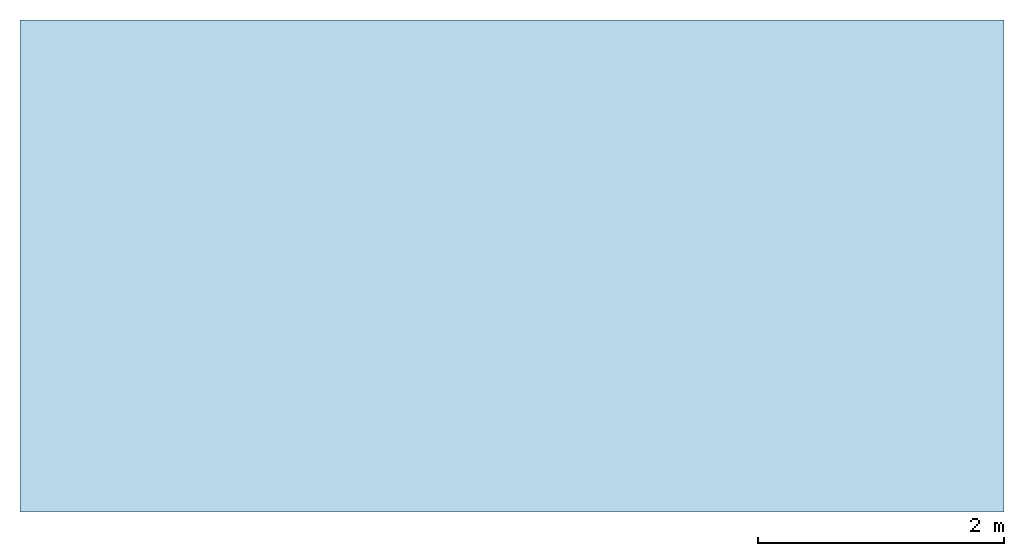
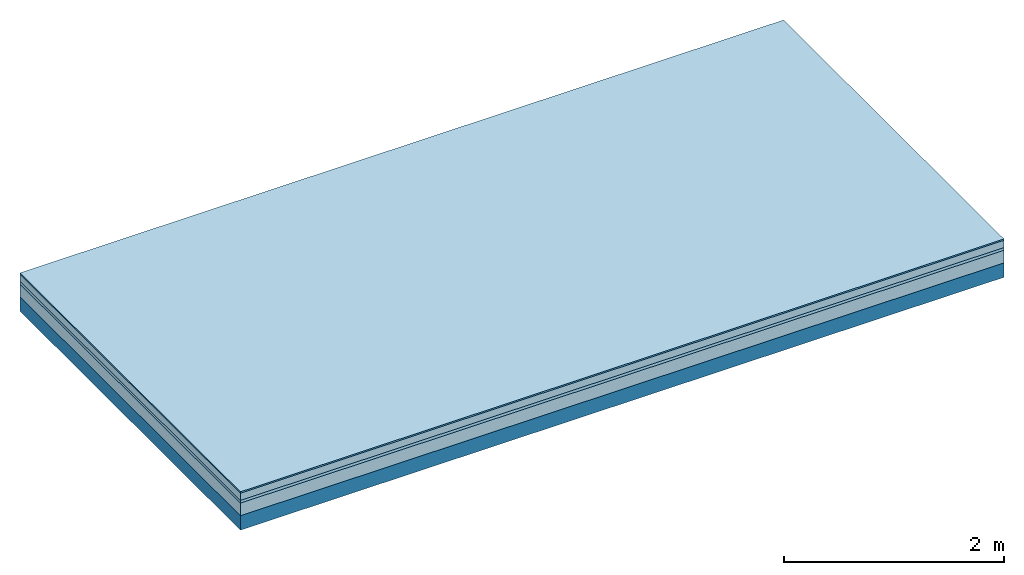
# One storey: 4 plates, 1 member, 1 element without a shape of its own.
"""IFC4 building model written with IfcOpenShell, lengths in metres."""

import ifcopenshell
import ifcopenshell.guid

model = None  # the IFC model being written
_history = None  # IfcOwnerHistory: only IFC2X3 demands one
_inside = {}  # id of a spatial element -> (the spatial element, [elements in it])
_under = {}  # id of a project, library or spatial element -> (it, [spatial elements below it])
_declared = {}  # id of a project -> (the project, [libraries it declares])
_typed = {}  # id of a type object -> (the type object, [elements of that type])
_made_of = {}  # id of a material, layer set ... -> (it, [elements and type objects made of it])


def new_model(schema):
    """Start an empty IFC model of exactly this schema.

    Asked for "IFC4X3", IfcOpenShell would pick the latest addendum, in which some entities
    have other attributes; the version numbers below select the first issue.
    IFC2X3 requires an IfcOwnerHistory on every rooted entity: one is made here for all.
    """
    global model, _history
    if schema == "IFC4X3":
        model = ifcopenshell.file(schema_version=(4, 3, 0, 0))
    else:
        model = ifcopenshell.file(schema=schema)
    _inside.clear()
    _under.clear()
    _declared.clear()
    _typed.clear()
    _made_of.clear()
    _history = None
    if model.schema == "IFC2X3":
        org = make("IfcOrganization", Name="unknown")
        user = make(
            "IfcPersonAndOrganization",
            ThePerson=make("IfcPerson", FamilyName="unknown"),
            TheOrganization=org,
        )
        app = make(
            "IfcApplication",
            ApplicationDeveloper=org,
            Version="unknown",
            ApplicationFullName="unknown",
            ApplicationIdentifier="unknown",
        )
        _history = make(
            "IfcOwnerHistory",
            OwningUser=user,
            OwningApplication=app,
            ChangeAction="ADDED",
            CreationDate=0,
        )
    return model


def make(cls, **values):
    """One entity of the class cls with the attributes given. An attribute that is None is left unset."""
    return model.create_entity(
        cls, **{name: value for name, value in values.items() if value is not None}
    )


def rooted(cls, **values):
    """An entity with a GlobalId (a new one), such as an element, a storey or a relation."""
    return make(cls, GlobalId=ifcopenshell.guid.new(), OwnerHistory=_history, **values)


def si_unit(unit_type, name, prefix=None):
    """IfcSIUnit, for example si_unit("LENGTHUNIT", "METRE", prefix="MILLI")."""
    return make("IfcSIUnit", UnitType=unit_type, Prefix=prefix, Name=name)


def derived_unit(unit_type, elements):
    """IfcDerivedUnit: a product of units, each with its exponent."""
    return make(
        "IfcDerivedUnit",
        Elements=[
            make("IfcDerivedUnitElement", Unit=unit, Exponent=power)
            for unit, power in elements
        ],
        UnitType=unit_type,
    )


def assignment(units):
    """IfcUnitAssignment: the units of a project."""
    return None if units is None else make("IfcUnitAssignment", Units=units)


def point(xyz):
    """IfcCartesianPoint."""
    return None if xyz is None else make("IfcCartesianPoint", Coordinates=xyz)


def direction(xyz):
    """IfcDirection."""
    return None if xyz is None else make("IfcDirection", DirectionRatios=xyz)


def frame(location, z_axis=None, x_axis=None):
    """IfcAxis2Placement3D, a coordinate frame: its origin and axes. An axis left out is left unset."""
    return make(
        "IfcAxis2Placement3D",
        Location=point(location),
        Axis=direction(z_axis),
        RefDirection=direction(x_axis),
    )


def frame_2d(location, x_axis=None):
    """IfcAxis2Placement2D, a coordinate frame in the plane: its origin and x axis."""
    return make(
        "IfcAxis2Placement2D", Location=point(location), RefDirection=direction(x_axis)
    )


def origin():
    """The frame at (0, 0, 0) with its axes left unset."""
    return frame((0.0, 0.0, 0.0))


def origin_with_axes():
    """The frame at (0, 0, 0) with the z axis (0, 0, 1) and the x axis (1, 0, 0) written out."""
    return frame((0.0, 0.0, 0.0), z_axis=(0.0, 0.0, 1.0), x_axis=(1.0, 0.0, 0.0))


def place(relative_to, where):
    """IfcLocalPlacement: puts the frame where relative to a parent placement (None: the world)."""
    return make(
        "IfcLocalPlacement", PlacementRelTo=relative_to, RelativePlacement=where
    )


def context(
    kind, dimensions, precision=None, world=None, true_north=None, identifier=None
):
    """IfcGeometricRepresentationContext, for example the 3D "Model" context."""
    return make(
        "IfcGeometricRepresentationContext",
        ContextIdentifier=identifier,
        ContextType=kind,
        CoordinateSpaceDimension=dimensions,
        Precision=precision,
        WorldCoordinateSystem=world,
        TrueNorth=true_north,
    )


def project(units=None, contexts=None):
    """IfcProject with its units and contexts."""
    return rooted(
        "IfcProject",
        Name="project",
        RepresentationContexts=contexts,
        UnitsInContext=assignment(units),
    )


def spatial(cls, under=None, at=None, **own):
    """A site, building, storey or space (cls), placed at a placement, below another one or the project."""
    s = rooted(cls, ObjectPlacement=at, **own)
    if under is not None:
        _under.setdefault(under.id(), (under, []))[1].append(s)
    return s


def profile(cls, at=None, kind="AREA", **sizes):
    """A parametric profile (cls). Its sizes go by their IFC names, for example OverallWidth=200.0."""
    return make(cls, ProfileType=kind, Position=at, **sizes)


def rectangle(**sizes):
    """IfcRectangleProfileDef."""
    return profile("IfcRectangleProfileDef", **sizes)


def extrude(swept, where, along, depth):
    """IfcExtrudedAreaSolid: the profile swept, set in the frame where, extruded along a direction by depth."""
    return make(
        "IfcExtrudedAreaSolid",
        SweptArea=swept,
        Position=where,
        ExtrudedDirection=direction(along),
        Depth=depth,
    )


def shape(context_of_items, identifier, shape_type, items):
    """IfcShapeRepresentation: the items that make up one representation, for example the "Body"."""
    return make(
        "IfcShapeRepresentation",
        ContextOfItems=context_of_items,
        RepresentationIdentifier=identifier,
        RepresentationType=shape_type,
        Items=items,
    )


def material(Name=None, Category=None):
    """IfcMaterial."""
    return make("IfcMaterial", Name=Name, Category=Category)


def layer(
    of_material, thickness, ventilated=None, Name=None, Category=None, Priority=None
):
    """IfcMaterialLayer: one layer of a wall or slab, of a material (None: an air gap)."""
    return make(
        "IfcMaterialLayer",
        Material=of_material,
        LayerThickness=thickness,
        IsVentilated=ventilated,
        Name=Name,
        Category=Category,
        Priority=Priority,
    )


def layer_set(layers, Name=None):
    """IfcMaterialLayerSet."""
    return make("IfcMaterialLayerSet", MaterialLayers=layers, LayerSetName=Name)


def made_of(thing, what):
    """Note that an element or type object is made of a material, layer set ...; save() writes the relation."""
    if what is not None:
        _made_of.setdefault(what.id(), (what, []))[1].append(thing)
    return thing


def type_object(cls, material=None, **own):
    """A type object (cls), such as IfcWallType, which elements share."""
    return made_of(rooted(cls, **own), material)


def element(
    cls,
    number,
    at=None,
    inside=None,
    cuts=None,
    type_object=None,
    material=None,
    context=None,
    identifier="Body",
    shape_type=None,
    held_by="IfcProductDefinitionShape",
    body=None,
    shapes=None,
    **own,
):
    """One element of the class cls, such as IfcWall. Its Tag is "e" and its number.

    at: its placement. inside: the storey or other place that contains it. cuts: it is an
    opening in that element (IfcRelVoidsElement). A single representation is given by context,
    identifier, shape_type and body (its items); several are given by shapes. held_by: the class
    of the entity that holds the representations. save() writes the other relations.
    """
    e = rooted(cls, Tag="e%d" % number, ObjectPlacement=at, **own)
    if body is not None:
        shapes = [shape(context, identifier, shape_type, body)]
    if shapes is not None:
        e.Representation = make(held_by, Representations=shapes)
    if inside is not None:
        _inside.setdefault(inside.id(), (inside, []))[1].append(e)
    if cuts is not None:
        rooted(
            "IfcRelVoidsElement", RelatingBuildingElement=cuts, RelatedOpeningElement=e
        )
    if type_object is not None:
        _typed.setdefault(type_object.id(), (type_object, []))[1].append(e)
    return made_of(e, material)


def aggregate(whole, parts):
    """IfcRelAggregates: a whole, such as a stair, and the parts it consists of."""
    return rooted("IfcRelAggregates", RelatingObject=whole, RelatedObjects=parts)


def save(model, path):
    """Write the relations noted so far, then the file.

    IfcRelAggregates (storeys below a building ...), IfcRelContainedInSpatialStructure (elements
    in a storey), IfcRelDefinesByType, IfcRelAssociatesMaterial and IfcRelDeclares: one each for
    every whole, place, type object, material and project.
    """
    for whole, parts in _under.values():
        aggregate(whole, parts)
    for where, things in _inside.values():
        rooted(
            "IfcRelContainedInSpatialStructure",
            RelatedElements=things,
            RelatingStructure=where,
        )
    for kind, things in _typed.values():
        rooted("IfcRelDefinesByType", RelatedObjects=things, RelatingType=kind)
    for what, things in _made_of.values():
        rooted("IfcRelAssociatesMaterial", RelatedObjects=things, RelatingMaterial=what)
    for by, libraries in _declared.values():
        rooted("IfcRelDeclares", RelatingContext=by, RelatedDefinitions=libraries)
    model.write(path)


model = new_model("IFC4")

# Units and contexts
plan_context = context("Plan", 3, precision=1e-05, world=origin(), true_north=direction((0.0, 1.0)))
model_context = context("Model", 3, precision=1e-05, world=origin(), true_north=direction((0.0, 1.0)))
ifc_project = project(units=[si_unit("LENGTHUNIT", "METRE"), derived_unit("SOUNDPRESSUREUNIT", [(si_unit("PRESSUREUNIT", "PASCAL", prefix="MICRO"), 0)]), si_unit("ENERGYUNIT", "JOULE", prefix="MEGA"), si_unit("MASSUNIT", "GRAM", prefix="KILO"), derived_unit("THERMALTRANSMITTANCEUNIT", [(si_unit("POWERUNIT", "WATT"), 1), (si_unit("AREAUNIT", "SQUARE_METRE"), -1), (si_unit("THERMODYNAMICTEMPERATUREUNIT", "KELVIN"), -1)]), derived_unit("AREADENSITYUNIT", [(si_unit("MASSUNIT", "GRAM", prefix="KILO"), 1), (si_unit("AREAUNIT", "SQUARE_METRE"), -1)]), derived_unit("USERDEFINED", [(si_unit("ENERGYUNIT", "JOULE", prefix="MEGA"), 1), (si_unit("AREAUNIT", "SQUARE_METRE"), -1)])], contexts=[plan_context, model_context])

# Site, building, storey
site = spatial("IfcSite", under=ifc_project)
building_placement = place(None, origin())
building = spatial("IfcBuilding", under=site, at=building_placement)
storey_placement = place(building_placement, origin())
storey = spatial("IfcBuildingStorey", under=building, at=storey_placement)

# Slab, member, plates
ifc_material_1 = material(Category="11.013")
ifc_layer_1 = layer(ifc_material_1, 0.015, Name="Flooring")
ifc_material_2 = material(Name="Cement screed", Category="04.006")
ifc_layer_2 = layer(ifc_material_2, 0.08, Name="On-material")
ifc_material_3 = material(Name="Wood fiber generic product", Category="10.009")
ifc_layer_3 = layer(ifc_material_3, 0.03, Name="Impact sound insulation")
ifc_material_4 = material(Category="01.002")
ifc_layer_4 = layer(ifc_material_4, 0.14, Name="Sub-floor")
ifc_material_5 = material(Name="Rigid, of the art")
ifc_layer_5 = layer(ifc_material_5, 0.0, Name="Bond")
ifc_layer_6 = layer(None, 0.16, Name="Supporting structure")
ifc_layer_set = layer_set([ifc_layer_1, ifc_layer_2, ifc_layer_3, ifc_layer_4, ifc_layer_5, ifc_layer_6])
slab_type = type_object("IfcSlabType", Name="A2202", PredefinedType="NOTDEFINED", material=ifc_layer_set)
slab_placement = place(None, frame((0.0, 0.0, 0.0), z_axis=(0.0, 0.0, -1.0), x_axis=(1.0, 0.0, 0.0)))
slab = element("IfcSlab", 1, at=slab_placement, inside=storey, type_object=slab_type, material=ifc_layer_set, Name="Slab #1")
ifc_material_6 = material(Name="Solid timber panel")
member_placement = place(slab_placement, origin())
member = element("IfcMember", 2, at=member_placement, material=ifc_material_6, Name="Supporting structure", context=plan_context, shape_type="SweptSolid", body=[
    extrude(rectangle(XDim=1.0, YDim=0.16, at=frame_2d((0.5, 0.08), x_axis=(1.0, 0.0))), frame((0.0, 4.0, 0.265), z_axis=(0.0, -1.0, 0.0), x_axis=(1.0, 0.0, 0.0)), (0.0, 0.0, 1.0), 4.0),
    extrude(rectangle(XDim=1.0, YDim=0.16, at=frame_2d((0.5, 0.08), x_axis=(1.0, 0.0))), frame((1.0, 4.0, 0.265), z_axis=(0.0, -1.0, 0.0), x_axis=(1.0, 0.0, 0.0)), (0.0, 0.0, 1.0), 4.0),
    extrude(rectangle(XDim=1.0, YDim=0.16, at=frame_2d((0.5, 0.08), x_axis=(1.0, 0.0))), frame((2.0, 4.0, 0.265), z_axis=(0.0, -1.0, 0.0), x_axis=(1.0, 0.0, 0.0)), (0.0, 0.0, 1.0), 4.0),
    extrude(rectangle(XDim=1.0, YDim=0.16, at=frame_2d((0.5, 0.08), x_axis=(1.0, 0.0))), frame((3.0, 4.0, 0.265), z_axis=(0.0, -1.0, 0.0), x_axis=(1.0, 0.0, 0.0)), (0.0, 0.0, 1.0), 4.0),
    extrude(rectangle(XDim=1.0, YDim=0.16, at=frame_2d((0.5, 0.08), x_axis=(1.0, 0.0))), frame((4.0, 4.0, 0.265), z_axis=(0.0, -1.0, 0.0), x_axis=(1.0, 0.0, 0.0)), (0.0, 0.0, 1.0), 4.0),
    extrude(rectangle(XDim=1.0, YDim=0.16, at=frame_2d((0.5, 0.08), x_axis=(1.0, 0.0))), frame((5.0, 4.0, 0.265), z_axis=(0.0, -1.0, 0.0), x_axis=(1.0, 0.0, 0.0)), (0.0, 0.0, 1.0), 4.0),
    extrude(rectangle(XDim=1.0, YDim=0.16, at=frame_2d((0.5, 0.08), x_axis=(1.0, 0.0))), frame((6.0, 4.0, 0.265), z_axis=(0.0, -1.0, 0.0), x_axis=(1.0, 0.0, 0.0)), (0.0, 0.0, 1.0), 4.0),
    extrude(rectangle(XDim=1.0, YDim=0.16, at=frame_2d((0.5, 0.08), x_axis=(1.0, 0.0))), frame((7.0, 4.0, 0.265), z_axis=(0.0, -1.0, 0.0), x_axis=(1.0, 0.0, 0.0)), (0.0, 0.0, 1.0), 4.0),
])
plate_1_placement = place(slab_placement, origin())
plate_1 = element("IfcPlate", 3, at=plate_1_placement, material=ifc_material_1, Name="Flooring", context=plan_context, shape_type="SweptSolid", body=[
    extrude(rectangle(XDim=8.0, YDim=4.0, at=frame_2d((4.0, 2.0), x_axis=(1.0, 0.0))), origin_with_axes(), (0.0, 0.0, 1.0), 0.015),
])
plate_2_placement = place(slab_placement, origin())
plate_2 = element("IfcPlate", 4, at=plate_2_placement, material=ifc_material_2, Name="On-material", context=plan_context, shape_type="SweptSolid", body=[
    extrude(rectangle(XDim=8.0, YDim=4.0, at=frame_2d((4.0, 2.0), x_axis=(1.0, 0.0))), frame((0.0, 0.0, 0.015), z_axis=(0.0, 0.0, 1.0), x_axis=(1.0, 0.0, 0.0)), (0.0, 0.0, 1.0), 0.08),
])
plate_3_placement = place(slab_placement, origin())
plate_3 = element("IfcPlate", 5, at=plate_3_placement, material=ifc_material_3, Name="Impact sound insulation", context=plan_context, shape_type="SweptSolid", body=[
    extrude(rectangle(XDim=8.0, YDim=4.0, at=frame_2d((4.0, 2.0), x_axis=(1.0, 0.0))), frame((0.0, 0.0, 0.095), z_axis=(0.0, 0.0, 1.0), x_axis=(1.0, 0.0, 0.0)), (0.0, 0.0, 1.0), 0.03),
])
plate_4_placement = place(slab_placement, origin())
plate_4 = element("IfcPlate", 6, at=plate_4_placement, material=ifc_material_4, Name="Sub-floor", context=plan_context, shape_type="SweptSolid", body=[
    extrude(rectangle(XDim=8.0, YDim=4.0, at=frame_2d((4.0, 2.0), x_axis=(1.0, 0.0))), frame((0.0, 0.0, 0.125), z_axis=(0.0, 0.0, 1.0), x_axis=(1.0, 0.0, 0.0)), (0.0, 0.0, 1.0), 0.14),
])
aggregate(slab, [plate_1, plate_2, plate_3, plate_4, member])

save(model, "model.ifc")
